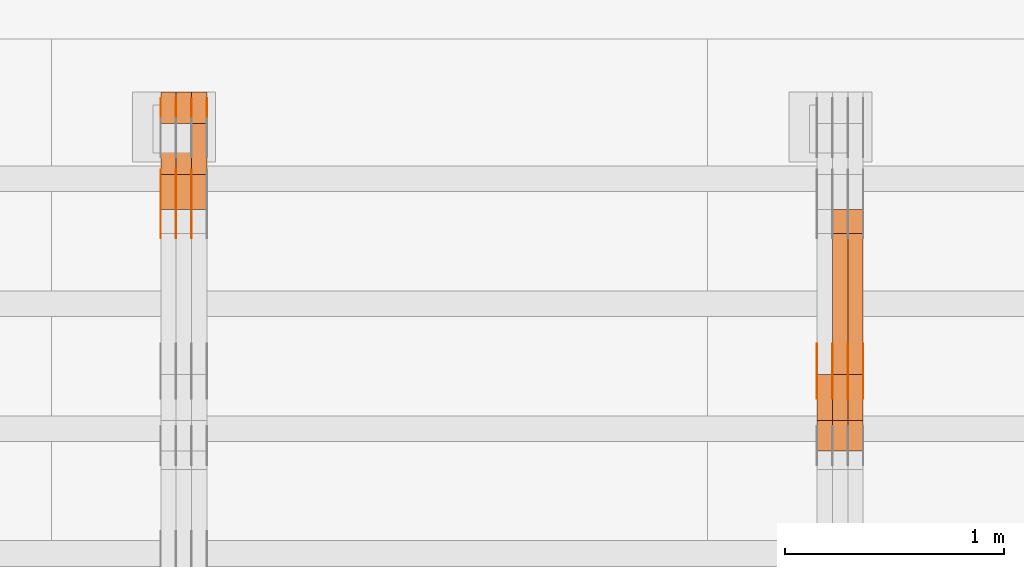
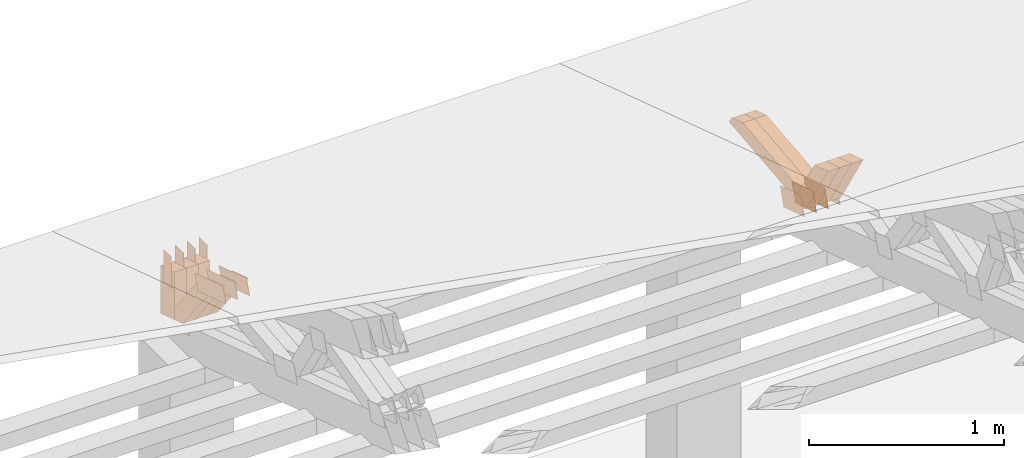
# One storey, part 349 of 385: 28 proxies.
"""IFC2X3 building model written with IfcOpenShell, lengths in millimetres."""

from ifc_helpers import new_model, entity, si_unit, converted_unit, derived_unit, direction, frame, frame_2d, origin, place, context, subcontext, project, spatial, polyline, rectangle, outline, extrude, source, transform, mapped, material, type_object, type_shapes, element, save


model = new_model("IFC2X3")

# Units and contexts
model_context = context("Model", 3, precision=0.01, world=origin(), true_north=direction((6.12303176911189e-17, 1.0)))
body_context = subcontext(model_context, "Body", "Model", "MODEL_VIEW")
ifc_project = project(units=[si_unit("LENGTHUNIT", "METRE", prefix="MILLI"), si_unit("AREAUNIT", "SQUARE_METRE"), si_unit("VOLUMEUNIT", "CUBIC_METRE"), converted_unit("PLANEANGLEUNIT", "DEGREE", entity("IfcRatioMeasure", 0.0174532925199433), si_unit("PLANEANGLEUNIT", "RADIAN"), dimensions=[0, 0, 0, 0, 0, 0, 0]), si_unit("MASSUNIT", "GRAM", prefix="KILO"), derived_unit("MASSDENSITYUNIT", [(si_unit("MASSUNIT", "GRAM", prefix="KILO"), 1), (si_unit("LENGTHUNIT", "METRE"), -3)]), si_unit("TIMEUNIT", "SECOND"), si_unit("FREQUENCYUNIT", "HERTZ"), si_unit("THERMODYNAMICTEMPERATUREUNIT", "DEGREE_CELSIUS"), derived_unit("THERMALTRANSMITTANCEUNIT", [(si_unit("MASSUNIT", "GRAM", prefix="KILO"), 1), (si_unit("THERMODYNAMICTEMPERATUREUNIT", "KELVIN"), -1), (si_unit("TIMEUNIT", "SECOND"), -3)]), derived_unit("VOLUMETRICFLOWRATEUNIT", [(si_unit("LENGTHUNIT", "METRE"), 3), (si_unit("TIMEUNIT", "SECOND"), -1)]), si_unit("ELECTRICCURRENTUNIT", "AMPERE"), si_unit("ELECTRICVOLTAGEUNIT", "VOLT"), si_unit("POWERUNIT", "WATT"), si_unit("FORCEUNIT", "NEWTON", prefix="KILO"), si_unit("ILLUMINANCEUNIT", "LUX"), si_unit("LUMINOUSFLUXUNIT", "LUMEN"), si_unit("LUMINOUSINTENSITYUNIT", "CANDELA"), derived_unit("USERDEFINED", [(si_unit("MASSUNIT", "GRAM", prefix="KILO"), -1), (si_unit("LENGTHUNIT", "METRE"), -2), (si_unit("TIMEUNIT", "SECOND"), 3), (si_unit("LUMINOUSFLUXUNIT", "LUMEN"), 1)]), derived_unit("LINEARVELOCITYUNIT", [(si_unit("LENGTHUNIT", "METRE"), 1), (si_unit("TIMEUNIT", "SECOND"), -1)]), si_unit("PRESSUREUNIT", "PASCAL"), derived_unit("USERDEFINED", [(si_unit("LENGTHUNIT", "METRE"), -2), (si_unit("MASSUNIT", "GRAM", prefix="KILO"), 1), (si_unit("TIMEUNIT", "SECOND"), -2)])], contexts=[model_context])

# Site, building, storey
site_placement = place(None, origin())
site = spatial("IfcSite", under=ifc_project, at=site_placement, CompositionType="ELEMENT")
building_placement = place(site_placement, origin())
building = spatial("IfcBuilding", under=site, at=building_placement, CompositionType="ELEMENT")
storey_placement = place(building_placement, origin())
storey = spatial("IfcBuildingStorey", under=building, at=storey_placement, Name="Default", CompositionType="ELEMENT", Elevation=0.0)

# Proxies
ifc_material_1 = material(Name="IfcSurfaceStyle #469548")
building_element_proxy_type_1 = type_object("IfcBuildingElementProxyType", PredefinedType="NOTDEFINED", material=ifc_material_1)
shared_shape_1 = source(origin(), body_context, "Body", "SweptSolid", [
    extrude(outline(polyline([(-112.50003853564, -60.0000121429077), (112.50002982902, -60.0000121429077), (112.500043250865, 60.0000121429077), (-112.500034544245, 60.0000121429077), (-112.50003853564, -60.0000121429077)])), frame((112.500056021398, 60.0000121429077, 0.0), z_axis=(0.0, 0.0, 1.0), x_axis=(-1.0, 0.0, 0.0)), (0.0, 0.0, 1.0), 1.3),
])
type_shapes(building_element_proxy_type_1, [shared_shape_1])
proxy_1_placement = place(building_placement, frame((39386.3, 25310.2182710495, 430.675738123044), z_axis=(-1.0, 0.0, 0.0), x_axis=(0.0, -0.951056516295124, 0.309016994375039)))
element("IfcBuildingElementProxy", 1, at=proxy_1_placement, inside=storey, type_object=building_element_proxy_type_1, material=ifc_material_1, context=body_context, shape_type="MappedRepresentation", body=[
    mapped(shared_shape_1, transform((0.0, 0.0, 0.0), scale=1.0)),
])
ifc_material_2 = material(Name="IfcSurfaceStyle #469491")
building_element_proxy_type_2 = type_object("IfcBuildingElementProxyType", PredefinedType="NOTDEFINED", material=ifc_material_2)
shared_shape_2 = source(origin(), body_context, "Body", "SweptSolid", [
    extrude(outline(polyline([(-112.50003853564, -60.0000121429077), (112.50002982902, -60.0000121429077), (112.500043250865, 60.0000121429077), (-112.500034544245, 60.0000121429077), (-112.50003853564, -60.0000121429077)])), frame((112.500056021398, 60.0000121429077, 0.0), z_axis=(0.0, 0.0, 1.0), x_axis=(-1.0, 0.0, 0.0)), (0.0, 0.0, 1.0), 1.3),
])
type_shapes(building_element_proxy_type_2, [shared_shape_2])
proxy_2_placement = place(building_placement, frame((39315.0, 25310.2182710495, 430.675738123044), z_axis=(-1.0, 0.0, 0.0), x_axis=(0.0, -0.951056516295124, 0.309016994375039)))
element("IfcBuildingElementProxy", 2, at=proxy_2_placement, inside=storey, type_object=building_element_proxy_type_2, material=ifc_material_2, context=body_context, shape_type="MappedRepresentation", body=[
    mapped(shared_shape_2, transform((0.0, 0.0, 0.0), scale=1.0)),
])
ifc_material_3 = material(Name="IfcSurfaceStyle #469434")
building_element_proxy_type_3 = type_object("IfcBuildingElementProxyType", PredefinedType="NOTDEFINED", material=ifc_material_3)
shared_shape_3 = source(origin(), body_context, "Body", "SweptSolid", [
    extrude(outline(polyline([(-112.50003853564, -60.0000121429077), (112.50002982902, -60.0000121429077), (112.500043250865, 60.0000121429077), (-112.500034544245, 60.0000121429077), (-112.50003853564, -60.0000121429077)])), frame((112.500056021398, 60.0000121429077, 0.0), z_axis=(0.0, 0.0, 1.0), x_axis=(-1.0, 0.0, 0.0)), (0.0, 0.0, 1.0), 1.3),
])
type_shapes(building_element_proxy_type_3, [shared_shape_3])
proxy_3_placement = place(building_placement, frame((39316.3, 25310.2182710495, 430.675738123044), z_axis=(-1.0, 0.0, 0.0), x_axis=(0.0, -0.951056516295124, 0.309016994375039)))
element("IfcBuildingElementProxy", 3, at=proxy_3_placement, inside=storey, type_object=building_element_proxy_type_3, material=ifc_material_3, context=body_context, shape_type="MappedRepresentation", body=[
    mapped(shared_shape_3, transform((0.0, 0.0, 0.0), scale=1.0)),
])
ifc_material_4 = material(Name="IfcSurfaceStyle #469377")
building_element_proxy_type_4 = type_object("IfcBuildingElementProxyType", PredefinedType="NOTDEFINED", material=ifc_material_4)
shared_shape_4 = source(origin(), body_context, "Body", "SweptSolid", [
    extrude(outline(polyline([(-112.50003853564, -60.0000121429077), (112.50002982902, -60.0000121429077), (112.500043250865, 60.0000121429077), (-112.500034544245, 60.0000121429077), (-112.50003853564, -60.0000121429077)])), frame((112.500056021398, 60.0000121429077, 0.0), z_axis=(0.0, 0.0, 1.0), x_axis=(-1.0, 0.0, 0.0)), (0.0, 0.0, 1.0), 1.29999999999998),
])
type_shapes(building_element_proxy_type_4, [shared_shape_4])
proxy_4_placement = place(building_placement, frame((39245.0, 25310.2182710495, 430.675738123044), z_axis=(-1.0, 0.0, 0.0), x_axis=(0.0, -0.951056516295124, 0.309016994375039)))
element("IfcBuildingElementProxy", 4, at=proxy_4_placement, inside=storey, type_object=building_element_proxy_type_4, material=ifc_material_4, context=body_context, shape_type="MappedRepresentation", body=[
    mapped(shared_shape_4, transform((0.0, 0.0, 0.0), scale=1.0)),
])
ifc_material_5 = material(Name="IfcSurfaceStyle #469320")
building_element_proxy_type_5 = type_object("IfcBuildingElementProxyType", PredefinedType="NOTDEFINED", material=ifc_material_5)
shared_shape_5 = source(origin(), body_context, "Body", "SweptSolid", [
    extrude(outline(polyline([(-112.50003853564, -60.0000121429077), (112.50002982902, -60.0000121429077), (112.500043250865, 60.0000121429077), (-112.500034544245, 60.0000121429077), (-112.50003853564, -60.0000121429077)])), frame((112.500056021398, 60.0000121429077, 0.0), z_axis=(0.0, 0.0, 1.0), x_axis=(-1.0, 0.0, 0.0)), (0.0, 0.0, 1.0), 1.29999999999998),
])
type_shapes(building_element_proxy_type_5, [shared_shape_5])
proxy_5_placement = place(building_placement, frame((39246.3, 25310.2182710495, 430.675738123044), z_axis=(-1.0, 0.0, 0.0), x_axis=(0.0, -0.951056516295124, 0.309016994375039)))
element("IfcBuildingElementProxy", 5, at=proxy_5_placement, inside=storey, type_object=building_element_proxy_type_5, material=ifc_material_5, context=body_context, shape_type="MappedRepresentation", body=[
    mapped(shared_shape_5, transform((0.0, 0.0, 0.0), scale=1.0)),
])
ifc_material_6 = material(Name="IfcSurfaceStyle #469263")
building_element_proxy_type_6 = type_object("IfcBuildingElementProxyType", PredefinedType="NOTDEFINED", material=ifc_material_6)
shared_shape_6 = source(origin(), body_context, "Body", "SweptSolid", [
    extrude(outline(polyline([(-112.50003853564, -60.0000121429077), (112.50002982902, -60.0000121429077), (112.500043250865, 60.0000121429077), (-112.500034544245, 60.0000121429077), (-112.50003853564, -60.0000121429077)])), frame((112.500056021398, 60.0000121429077, 0.0), z_axis=(0.0, 0.0, 1.0), x_axis=(-1.0, 0.0, 0.0)), (0.0, 0.0, 1.0), 1.29999999999999),
])
type_shapes(building_element_proxy_type_6, [shared_shape_6])
proxy_6_placement = place(building_placement, frame((39175.0, 25310.2182710495, 430.675738123044), z_axis=(-1.0, 0.0, 0.0), x_axis=(0.0, -0.951056516295124, 0.309016994375039)))
element("IfcBuildingElementProxy", 6, at=proxy_6_placement, inside=storey, type_object=building_element_proxy_type_6, material=ifc_material_6, context=body_context, shape_type="MappedRepresentation", body=[
    mapped(shared_shape_6, transform((0.0, 0.0, 0.0), scale=1.0)),
])
ifc_material_7 = material(Name="IfcSurfaceStyle #457506")
building_element_proxy_type_7 = type_object("IfcBuildingElementProxyType", Name="T1-W31 457504", PredefinedType="NOTDEFINED", material=ifc_material_7)
shared_shape_7 = source(origin(), body_context, "Body", "SweptSolid", [
    extrude(outline(polyline([(-201.245318299844, -47.5000121670808), (204.413774229459, -47.5000121670808), (182.034306640891, 5.35692244583164e-05), (126.70380769348, 47.4999853824686), (-311.906570263987, 47.4999853824686), (-201.245318299844, -47.5000121670808)])), frame((204.413774229459, 47.5002684334588, 0.0), z_axis=(0.0, 0.0, 1.0), x_axis=(-1.0, 0.0, 0.0)), (0.0, 0.0, 1.0), 70.0),
])
type_shapes(building_element_proxy_type_7, [shared_shape_7])
proxy_7_placement = place(building_placement, frame((39385.0, 25127.5652647985, 487.27008059185), z_axis=(-1.0, 0.0, 0.0), x_axis=(0.0, -0.520333970303023, 0.853962855953755)))
element("IfcBuildingElementProxy", 7, at=proxy_7_placement, inside=storey, type_object=building_element_proxy_type_7, material=ifc_material_7, Name="T1-W31", context=body_context, shape_type="MappedRepresentation", body=[
    mapped(shared_shape_7, transform((0.0, 0.0, 0.0), scale=1.0)),
])
ifc_material_8 = material(Name="IfcSurfaceStyle #457440")
building_element_proxy_type_8 = type_object("IfcBuildingElementProxyType", Name="T1-W31 457438", PredefinedType="NOTDEFINED", material=ifc_material_8)
shared_shape_8 = source(origin(), body_context, "Body", "SweptSolid", [
    extrude(outline(polyline([(-201.245318299844, -47.5000121670808), (204.413774229459, -47.5000121670808), (182.034306640891, 5.35692244583164e-05), (126.70380769348, 47.4999853824686), (-311.906570263987, 47.4999853824686), (-201.245318299844, -47.5000121670808)])), frame((204.413774229459, 47.5002684334588, 0.0), z_axis=(0.0, 0.0, 1.0), x_axis=(-1.0, 0.0, 0.0)), (0.0, 0.0, 1.0), 70.0),
])
type_shapes(building_element_proxy_type_8, [shared_shape_8])
proxy_8_placement = place(building_placement, frame((39315.0, 25127.5652647985, 487.27008059185), z_axis=(-1.0, 0.0, 0.0), x_axis=(0.0, -0.520333970303023, 0.853962855953755)))
element("IfcBuildingElementProxy", 8, at=proxy_8_placement, inside=storey, type_object=building_element_proxy_type_8, material=ifc_material_8, Name="T1-W31", context=body_context, shape_type="MappedRepresentation", body=[
    mapped(shared_shape_8, transform((0.0, 0.0, 0.0), scale=1.0)),
])
ifc_material_9 = material(Name="IfcSurfaceStyle #457374")
building_element_proxy_type_9 = type_object("IfcBuildingElementProxyType", Name="T1-W31 457372", PredefinedType="NOTDEFINED", material=ifc_material_9)
shared_shape_9 = source(origin(), body_context, "Body", "SweptSolid", [
    extrude(outline(polyline([(-201.245318299844, -47.5000121670808), (204.413774229459, -47.5000121670808), (182.034306640891, 5.35692244583164e-05), (126.70380769348, 47.4999853824686), (-311.906570263987, 47.4999853824686), (-201.245318299844, -47.5000121670808)])), frame((204.413774229459, 47.5002684334588, 0.0), z_axis=(0.0, 0.0, 1.0), x_axis=(-1.0, 0.0, 0.0)), (0.0, 0.0, 1.0), 70.0),
])
type_shapes(building_element_proxy_type_9, [shared_shape_9])
proxy_9_placement = place(building_placement, frame((39245.0, 25127.5652647985, 487.27008059185), z_axis=(-1.0, 0.0, 0.0), x_axis=(0.0, -0.520333970303023, 0.853962855953755)))
element("IfcBuildingElementProxy", 9, at=proxy_9_placement, inside=storey, type_object=building_element_proxy_type_9, material=ifc_material_9, Name="T1-W31", context=body_context, shape_type="MappedRepresentation", body=[
    mapped(shared_shape_9, transform((0.0, 0.0, 0.0), scale=1.0)),
])
ifc_material_10 = material(Name="IfcSurfaceStyle #457110")
building_element_proxy_type_10 = type_object("IfcBuildingElementProxyType", Name="T1-W4 457108", PredefinedType="NOTDEFINED", material=ifc_material_10)
shared_shape_10 = source(origin(), body_context, "Body", "SweptSolid", [
    extrude(outline(polyline([(-510.077325435179, -47.4999981284922), (188.854793418912, -47.4999981284922), (294.906688207675, 1.67015383116809e-05), (324.289382923648, 47.499989777723), (-297.973539115057, 47.4999897777231), (-510.077325435179, -47.4999981284922)])), frame((324.289382923648, 47.5000278316275, 0.0), z_axis=(0.0, 0.0, 1.0), x_axis=(-1.0, 0.0, 0.0)), (0.0, 0.0, 1.0), 70.0),
])
type_shapes(building_element_proxy_type_10, [shared_shape_10])
proxy_10_placement = place(building_placement, frame((39385.0, 25996.2241251556, 525.69905884318), z_axis=(-1.0, 0.0, 0.0), x_axis=(0.0, -0.994287125203057, -0.106738524701444)))
element("IfcBuildingElementProxy", 10, at=proxy_10_placement, inside=storey, type_object=building_element_proxy_type_10, material=ifc_material_10, Name="T1-W4", context=body_context, shape_type="MappedRepresentation", body=[
    mapped(shared_shape_10, transform((0.0, 0.0, 0.0), scale=1.0)),
])
ifc_material_11 = material(Name="IfcSurfaceStyle #457044")
building_element_proxy_type_11 = type_object("IfcBuildingElementProxyType", Name="T1-W4 457042", PredefinedType="NOTDEFINED", material=ifc_material_11)
shared_shape_11 = source(origin(), body_context, "Body", "SweptSolid", [
    extrude(outline(polyline([(-510.077325435179, -47.4999981284922), (188.854793418912, -47.4999981284922), (294.906688207675, 1.67015383116809e-05), (324.289382923648, 47.499989777723), (-297.973539115057, 47.4999897777231), (-510.077325435179, -47.4999981284922)])), frame((324.289382923648, 47.5000278316275, 0.0), z_axis=(0.0, 0.0, 1.0), x_axis=(-1.0, 0.0, 0.0)), (0.0, 0.0, 1.0), 70.0),
])
type_shapes(building_element_proxy_type_11, [shared_shape_11])
proxy_11_placement = place(building_placement, frame((39315.0, 25996.2241251556, 525.69905884318), z_axis=(-1.0, 0.0, 0.0), x_axis=(0.0, -0.994287125203057, -0.106738524701444)))
element("IfcBuildingElementProxy", 11, at=proxy_11_placement, inside=storey, type_object=building_element_proxy_type_11, material=ifc_material_11, Name="T1-W4", context=body_context, shape_type="MappedRepresentation", body=[
    mapped(shared_shape_11, transform((0.0, 0.0, 0.0), scale=1.0)),
])
ifc_material_12 = material(Name="IfcSurfaceStyle #434375")
building_element_proxy_type_12 = type_object("IfcBuildingElementProxyType", PredefinedType="NOTDEFINED", material=ifc_material_12)
shared_shape_12 = source(origin(), body_context, "Body", "SweptSolid", [
    extrude(outline(polyline([(-149.999901061401, -48.0000057587028), (150.000035297123, -48.0000057587028), (149.999910491851, 48.0000057587028), (-150.000044727574, 48.0000057587028), (-149.999901061401, -48.0000057587028)])), frame((150.000035297123, 48.0000632585775, 0.0), z_axis=(0.0, 0.0, 1.0), x_axis=(-1.0, 0.0, 0.0)), (0.0, 0.0, 1.0), 1.29999999999999),
])
type_shapes(building_element_proxy_type_12, [shared_shape_12])
proxy_12_placement = place(building_placement, frame((36315.0, 26115.0176968219, 469.58296924555), z_axis=(-1.0, 0.0, 0.0), x_axis=(0.0, -0.951056516295154, 0.309016994374948)))
element("IfcBuildingElementProxy", 12, at=proxy_12_placement, inside=storey, type_object=building_element_proxy_type_12, material=ifc_material_12, context=body_context, shape_type="MappedRepresentation", body=[
    mapped(shared_shape_12, transform((0.0, 0.0, 0.0), scale=1.0)),
])
ifc_material_13 = material(Name="IfcSurfaceStyle #434318")
building_element_proxy_type_13 = type_object("IfcBuildingElementProxyType", PredefinedType="NOTDEFINED", material=ifc_material_13)
shared_shape_13 = source(origin(), body_context, "Body", "SweptSolid", [
    extrude(outline(polyline([(-149.999901061401, -48.0000057587028), (150.000035297123, -48.0000057587028), (149.999910491851, 48.0000057587028), (-150.000044727574, 48.0000057587028), (-149.999901061401, -48.0000057587028)])), frame((150.000035297123, 48.0000632585775, 0.0), z_axis=(0.0, 0.0, 1.0), x_axis=(-1.0, 0.0, 0.0)), (0.0, 0.0, 1.0), 1.29999999999999),
])
type_shapes(building_element_proxy_type_13, [shared_shape_13])
proxy_13_placement = place(building_placement, frame((36316.3, 26115.0176968219, 469.58296924555), z_axis=(-1.0, 0.0, 0.0), x_axis=(0.0, -0.951056516295154, 0.309016994374948)))
element("IfcBuildingElementProxy", 13, at=proxy_13_placement, inside=storey, type_object=building_element_proxy_type_13, material=ifc_material_13, context=body_context, shape_type="MappedRepresentation", body=[
    mapped(shared_shape_13, transform((0.0, 0.0, 0.0), scale=1.0)),
])
ifc_material_14 = material(Name="IfcSurfaceStyle #434261")
building_element_proxy_type_14 = type_object("IfcBuildingElementProxyType", PredefinedType="NOTDEFINED", material=ifc_material_14)
shared_shape_14 = source(origin(), body_context, "Body", "SweptSolid", [
    extrude(outline(polyline([(-149.999901061401, -48.0000057587028), (150.000035297123, -48.0000057587028), (149.999910491851, 48.0000057587028), (-150.000044727574, 48.0000057587028), (-149.999901061401, -48.0000057587028)])), frame((150.000035297123, 48.0000632585775, 0.0), z_axis=(0.0, 0.0, 1.0), x_axis=(-1.0, 0.0, 0.0)), (0.0, 0.0, 1.0), 1.29999999999998),
])
type_shapes(building_element_proxy_type_14, [shared_shape_14])
proxy_14_placement = place(building_placement, frame((36245.0, 26115.0176968219, 469.58296924555), z_axis=(-1.0, 0.0, 0.0), x_axis=(0.0, -0.951056516295154, 0.309016994374948)))
element("IfcBuildingElementProxy", 14, at=proxy_14_placement, inside=storey, type_object=building_element_proxy_type_14, material=ifc_material_14, context=body_context, shape_type="MappedRepresentation", body=[
    mapped(shared_shape_14, transform((0.0, 0.0, 0.0), scale=1.0)),
])
ifc_material_15 = material(Name="IfcSurfaceStyle #434204")
building_element_proxy_type_15 = type_object("IfcBuildingElementProxyType", PredefinedType="NOTDEFINED", material=ifc_material_15)
shared_shape_15 = source(origin(), body_context, "Body", "SweptSolid", [
    extrude(outline(polyline([(-149.999901061401, -48.0000057587028), (150.000035297123, -48.0000057587028), (149.999910491851, 48.0000057587028), (-150.000044727574, 48.0000057587028), (-149.999901061401, -48.0000057587028)])), frame((150.000035297123, 48.0000632585775, 0.0), z_axis=(0.0, 0.0, 1.0), x_axis=(-1.0, 0.0, 0.0)), (0.0, 0.0, 1.0), 1.29999999999998),
])
type_shapes(building_element_proxy_type_15, [shared_shape_15])
proxy_15_placement = place(building_placement, frame((36246.3, 26115.0176968219, 469.58296924555), z_axis=(-1.0, 0.0, 0.0), x_axis=(0.0, -0.951056516295154, 0.309016994374948)))
element("IfcBuildingElementProxy", 15, at=proxy_15_placement, inside=storey, type_object=building_element_proxy_type_15, material=ifc_material_15, context=body_context, shape_type="MappedRepresentation", body=[
    mapped(shared_shape_15, transform((0.0, 0.0, 0.0), scale=1.0)),
])
ifc_material_16 = material(Name="IfcSurfaceStyle #434147")
building_element_proxy_type_16 = type_object("IfcBuildingElementProxyType", PredefinedType="NOTDEFINED", material=ifc_material_16)
shared_shape_16 = source(origin(), body_context, "Body", "SweptSolid", [
    extrude(outline(polyline([(-149.999901061401, -48.0000057587028), (150.000035297123, -48.0000057587028), (149.999910491851, 48.0000057587028), (-150.000044727574, 48.0000057587028), (-149.999901061401, -48.0000057587028)])), frame((150.000035297123, 48.0000632585775, 0.0), z_axis=(0.0, 0.0, 1.0), x_axis=(-1.0, 0.0, 0.0)), (0.0, 0.0, 1.0), 1.29999999999998),
])
type_shapes(building_element_proxy_type_16, [shared_shape_16])
proxy_16_placement = place(building_placement, frame((36175.0, 26115.0176968219, 469.58296924555), z_axis=(-1.0, 0.0, 0.0), x_axis=(0.0, -0.951056516295154, 0.309016994374948)))
element("IfcBuildingElementProxy", 16, at=proxy_16_placement, inside=storey, type_object=building_element_proxy_type_16, material=ifc_material_16, context=body_context, shape_type="MappedRepresentation", body=[
    mapped(shared_shape_16, transform((0.0, 0.0, 0.0), scale=1.0)),
])
ifc_material_17 = material(Name="IfcSurfaceStyle #434090")
building_element_proxy_type_17 = type_object("IfcBuildingElementProxyType", PredefinedType="NOTDEFINED", material=ifc_material_17)
shared_shape_17 = source(origin(), body_context, "Body", "SweptSolid", [
    extrude(rectangle(XDim=200.0, YDim=84.0000000000005, at=frame_2d((-2.1316282072803e-14, 1.06581410364015e-14), x_axis=(1.0, 0.0))), frame((100.0, 42.0, 0.0), z_axis=(0.0, 0.0, 1.0), x_axis=(-1.0, 0.0, 0.0)), (0.0, 0.0, 1.0), 1.3),
])
type_shapes(building_element_proxy_type_17, [shared_shape_17])
proxy_17_placement = place(building_placement, frame((36386.3, 26469.5000000002, 518.521545410156), z_axis=(-1.0, 0.0, 0.0), x_axis=(0.0, 0.0, -1.0)))
element("IfcBuildingElementProxy", 17, at=proxy_17_placement, inside=storey, type_object=building_element_proxy_type_17, material=ifc_material_17, context=body_context, shape_type="MappedRepresentation", body=[
    mapped(shared_shape_17, transform((0.0, 0.0, 0.0), scale=1.0)),
])
ifc_material_18 = material(Name="IfcSurfaceStyle #434033")
building_element_proxy_type_18 = type_object("IfcBuildingElementProxyType", PredefinedType="NOTDEFINED", material=ifc_material_18)
shared_shape_18 = source(origin(), body_context, "Body", "SweptSolid", [
    extrude(rectangle(XDim=200.0, YDim=84.0000000000005, at=frame_2d((-2.1316282072803e-14, 1.06581410364015e-14), x_axis=(1.0, 0.0))), frame((100.0, 42.0, 0.0), z_axis=(0.0, 0.0, 1.0), x_axis=(-1.0, 0.0, 0.0)), (0.0, 0.0, 1.0), 1.3),
])
type_shapes(building_element_proxy_type_18, [shared_shape_18])
proxy_18_placement = place(building_placement, frame((36315.0, 26469.5000000002, 518.521545410156), z_axis=(-1.0, 0.0, 0.0), x_axis=(0.0, 0.0, -1.0)))
element("IfcBuildingElementProxy", 18, at=proxy_18_placement, inside=storey, type_object=building_element_proxy_type_18, material=ifc_material_18, context=body_context, shape_type="MappedRepresentation", body=[
    mapped(shared_shape_18, transform((0.0, 0.0, 0.0), scale=1.0)),
])
ifc_material_19 = material(Name="IfcSurfaceStyle #433976")
building_element_proxy_type_19 = type_object("IfcBuildingElementProxyType", PredefinedType="NOTDEFINED", material=ifc_material_19)
shared_shape_19 = source(origin(), body_context, "Body", "SweptSolid", [
    extrude(rectangle(XDim=200.0, YDim=84.0000000000005, at=frame_2d((-2.1316282072803e-14, 1.06581410364015e-14), x_axis=(1.0, 0.0))), frame((100.0, 42.0, 0.0), z_axis=(0.0, 0.0, 1.0), x_axis=(-1.0, 0.0, 0.0)), (0.0, 0.0, 1.0), 1.3),
])
type_shapes(building_element_proxy_type_19, [shared_shape_19])
proxy_19_placement = place(building_placement, frame((36316.3, 26469.5000000002, 518.521545410156), z_axis=(-1.0, 0.0, 0.0), x_axis=(0.0, 0.0, -1.0)))
element("IfcBuildingElementProxy", 19, at=proxy_19_placement, inside=storey, type_object=building_element_proxy_type_19, material=ifc_material_19, context=body_context, shape_type="MappedRepresentation", body=[
    mapped(shared_shape_19, transform((0.0, 0.0, 0.0), scale=1.0)),
])
ifc_material_20 = material(Name="IfcSurfaceStyle #433919")
building_element_proxy_type_20 = type_object("IfcBuildingElementProxyType", PredefinedType="NOTDEFINED", material=ifc_material_20)
shared_shape_20 = source(origin(), body_context, "Body", "SweptSolid", [
    extrude(rectangle(XDim=200.0, YDim=84.0000000000005, at=frame_2d((-2.1316282072803e-14, 1.06581410364015e-14), x_axis=(1.0, 0.0))), frame((100.0, 42.0, 0.0), z_axis=(0.0, 0.0, 1.0), x_axis=(-1.0, 0.0, 0.0)), (0.0, 0.0, 1.0), 1.29999999999998),
])
type_shapes(building_element_proxy_type_20, [shared_shape_20])
proxy_20_placement = place(building_placement, frame((36245.0, 26469.5000000002, 518.521545410156), z_axis=(-1.0, 0.0, 0.0), x_axis=(0.0, 0.0, -1.0)))
element("IfcBuildingElementProxy", 20, at=proxy_20_placement, inside=storey, type_object=building_element_proxy_type_20, material=ifc_material_20, context=body_context, shape_type="MappedRepresentation", body=[
    mapped(shared_shape_20, transform((0.0, 0.0, 0.0), scale=1.0)),
])
ifc_material_21 = material(Name="IfcSurfaceStyle #433862")
building_element_proxy_type_21 = type_object("IfcBuildingElementProxyType", PredefinedType="NOTDEFINED", material=ifc_material_21)
shared_shape_21 = source(origin(), body_context, "Body", "SweptSolid", [
    extrude(rectangle(XDim=200.0, YDim=84.0000000000005, at=frame_2d((-2.1316282072803e-14, 1.06581410364015e-14), x_axis=(1.0, 0.0))), frame((100.0, 42.0, 0.0), z_axis=(0.0, 0.0, 1.0), x_axis=(-1.0, 0.0, 0.0)), (0.0, 0.0, 1.0), 1.29999999999998),
])
type_shapes(building_element_proxy_type_21, [shared_shape_21])
proxy_21_placement = place(building_placement, frame((36246.3, 26469.5000000002, 518.521545410156), z_axis=(-1.0, 0.0, 0.0), x_axis=(0.0, 0.0, -1.0)))
element("IfcBuildingElementProxy", 21, at=proxy_21_placement, inside=storey, type_object=building_element_proxy_type_21, material=ifc_material_21, context=body_context, shape_type="MappedRepresentation", body=[
    mapped(shared_shape_21, transform((0.0, 0.0, 0.0), scale=1.0)),
])
ifc_material_22 = material(Name="IfcSurfaceStyle #433805")
building_element_proxy_type_22 = type_object("IfcBuildingElementProxyType", PredefinedType="NOTDEFINED", material=ifc_material_22)
shared_shape_22 = source(origin(), body_context, "Body", "SweptSolid", [
    extrude(rectangle(XDim=200.0, YDim=84.0000000000005, at=frame_2d((-2.1316282072803e-14, 1.06581410364015e-14), x_axis=(1.0, 0.0))), frame((100.0, 42.0, 0.0), z_axis=(0.0, 0.0, 1.0), x_axis=(-1.0, 0.0, 0.0)), (0.0, 0.0, 1.0), 1.29999999999999),
])
type_shapes(building_element_proxy_type_22, [shared_shape_22])
proxy_22_placement = place(building_placement, frame((36175.0, 26469.5000000002, 518.521545410156), z_axis=(-1.0, 0.0, 0.0), x_axis=(0.0, 0.0, -1.0)))
element("IfcBuildingElementProxy", 22, at=proxy_22_placement, inside=storey, type_object=building_element_proxy_type_22, material=ifc_material_22, context=body_context, shape_type="MappedRepresentation", body=[
    mapped(shared_shape_22, transform((0.0, 0.0, 0.0), scale=1.0)),
])
ifc_material_23 = material(Name="IfcSurfaceStyle #422282")
building_element_proxy_type_23 = type_object("IfcBuildingElementProxyType", Name="T1-W21 422280", PredefinedType="NOTDEFINED", material=ifc_material_23)
shared_shape_23 = source(origin(), body_context, "Body", "SweptSolid", [
    extrude(outline(polyline([(-209.199362597501, -47.5000308982766), (168.813164734153, -47.5000308982766), (229.900717355638, -2.18385470334148e-05), (159.828709317766, 47.5000418175501), (-349.343228810055, 47.5000418175502), (-209.199362597501, -47.5000308982766)])), frame((229.900720156071, 47.5000418175501, 0.0), z_axis=(0.0, 0.0, 1.0), x_axis=(-1.0, 0.0, 0.0)), (0.0, 0.0, 1.0), 70.0),
])
type_shapes(building_element_proxy_type_23, [shared_shape_23])
proxy_23_placement = place(building_placement, frame((36385.0, 26317.5019908272, 112.518372832984), z_axis=(-1.0, 0.0, 0.0), x_axis=(0.0, -0.613839629272042, 0.789430750310097)))
element("IfcBuildingElementProxy", 23, at=proxy_23_placement, inside=storey, type_object=building_element_proxy_type_23, material=ifc_material_23, Name="T1-W21", context=body_context, shape_type="MappedRepresentation", body=[
    mapped(shared_shape_23, transform((0.0, 0.0, 0.0), scale=1.0)),
])
ifc_material_24 = material(Name="IfcSurfaceStyle #422216")
building_element_proxy_type_24 = type_object("IfcBuildingElementProxyType", Name="T1-W21 422214", PredefinedType="NOTDEFINED", material=ifc_material_24)
shared_shape_24 = source(origin(), body_context, "Body", "SweptSolid", [
    extrude(outline(polyline([(-209.199362597501, -47.5000308982766), (168.813164734153, -47.5000308982766), (229.900717355638, -2.18385470334148e-05), (159.828709317766, 47.5000418175501), (-349.343228810055, 47.5000418175502), (-209.199362597501, -47.5000308982766)])), frame((229.900720156071, 47.5000418175501, 0.0), z_axis=(0.0, 0.0, 1.0), x_axis=(-1.0, 0.0, 0.0)), (0.0, 0.0, 1.0), 70.0),
])
type_shapes(building_element_proxy_type_24, [shared_shape_24])
proxy_24_placement = place(building_placement, frame((36315.0, 26317.5019908272, 112.518372832984), z_axis=(-1.0, 0.0, 0.0), x_axis=(0.0, -0.613839629272042, 0.789430750310097)))
element("IfcBuildingElementProxy", 24, at=proxy_24_placement, inside=storey, type_object=building_element_proxy_type_24, material=ifc_material_24, Name="T1-W21", context=body_context, shape_type="MappedRepresentation", body=[
    mapped(shared_shape_24, transform((0.0, 0.0, 0.0), scale=1.0)),
])
ifc_material_25 = material(Name="IfcSurfaceStyle #422150")
building_element_proxy_type_25 = type_object("IfcBuildingElementProxyType", Name="T1-W21 422148", PredefinedType="NOTDEFINED", material=ifc_material_25)
shared_shape_25 = source(origin(), body_context, "Body", "SweptSolid", [
    extrude(outline(polyline([(-209.199362597501, -47.5000308982766), (168.813164734153, -47.5000308982766), (229.900717355638, -2.18385470334148e-05), (159.828709317766, 47.5000418175501), (-349.343228810055, 47.5000418175502), (-209.199362597501, -47.5000308982766)])), frame((229.900720156071, 47.5000418175501, 0.0), z_axis=(0.0, 0.0, 1.0), x_axis=(-1.0, 0.0, 0.0)), (0.0, 0.0, 1.0), 70.0),
])
type_shapes(building_element_proxy_type_25, [shared_shape_25])
proxy_25_placement = place(building_placement, frame((36245.0, 26317.5019908272, 112.518372832984), z_axis=(-1.0, 0.0, 0.0), x_axis=(0.0, -0.613839629272042, 0.789430750310097)))
element("IfcBuildingElementProxy", 25, at=proxy_25_placement, inside=storey, type_object=building_element_proxy_type_25, material=ifc_material_25, Name="T1-W21", context=body_context, shape_type="MappedRepresentation", body=[
    mapped(shared_shape_25, transform((0.0, 0.0, 0.0), scale=1.0)),
])
ifc_material_26 = material(Name="IfcSurfaceStyle #421715")
building_element_proxy_type_26 = type_object("IfcBuildingElementProxyType", Name="T1-E2 421713", PredefinedType="NOTDEFINED", material=ifc_material_26)
shared_shape_26 = source(origin(), body_context, "Body", "SweptSolid", [
    extrude(outline(polyline([(-126.644535064697, -72.4999999999998), (173.757884979248, -72.4999999999998), (126.644542694092, 72.4999999999998), (-173.757892608642, 72.4999999999998), (-126.644535064697, -72.4999999999998)])), frame((173.757890653796, 72.5000000000002, 0.0), z_axis=(0.0, 0.0, 1.0), x_axis=(-1.0, 0.0, 0.0)), (0.0, 0.0, 1.0), 70.0),
])
type_shapes(building_element_proxy_type_26, [shared_shape_26])
proxy_26_placement = place(building_placement, frame((36385.0, 26500.0, 442.078222227283), z_axis=(-1.0, 0.0, 0.0), x_axis=(0.0, 0.0, -1.0)))
element("IfcBuildingElementProxy", 26, at=proxy_26_placement, inside=storey, type_object=building_element_proxy_type_26, material=ifc_material_26, Name="T1-E2", context=body_context, shape_type="MappedRepresentation", body=[
    mapped(shared_shape_26, transform((0.0, 0.0, 0.0), scale=1.0)),
])
ifc_material_27 = material(Name="IfcSurfaceStyle #421658")
building_element_proxy_type_27 = type_object("IfcBuildingElementProxyType", Name="T1-E2 421656", PredefinedType="NOTDEFINED", material=ifc_material_27)
shared_shape_27 = source(origin(), body_context, "Body", "SweptSolid", [
    extrude(outline(polyline([(-126.644535064697, -72.4999999999998), (173.757884979248, -72.4999999999998), (126.644542694092, 72.4999999999998), (-173.757892608642, 72.4999999999998), (-126.644535064697, -72.4999999999998)])), frame((173.757890653796, 72.5000000000002, 0.0), z_axis=(0.0, 0.0, 1.0), x_axis=(-1.0, 0.0, 0.0)), (0.0, 0.0, 1.0), 70.0),
])
type_shapes(building_element_proxy_type_27, [shared_shape_27])
proxy_27_placement = place(building_placement, frame((36315.0, 26500.0, 442.078222227283), z_axis=(-1.0, 0.0, 0.0), x_axis=(0.0, 0.0, -1.0)))
element("IfcBuildingElementProxy", 27, at=proxy_27_placement, inside=storey, type_object=building_element_proxy_type_27, material=ifc_material_27, Name="T1-E2", context=body_context, shape_type="MappedRepresentation", body=[
    mapped(shared_shape_27, transform((0.0, 0.0, 0.0), scale=1.0)),
])
ifc_material_28 = material(Name="IfcSurfaceStyle #421601")
building_element_proxy_type_28 = type_object("IfcBuildingElementProxyType", Name="T1-E2 421599", PredefinedType="NOTDEFINED", material=ifc_material_28)
shared_shape_28 = source(origin(), body_context, "Body", "SweptSolid", [
    extrude(outline(polyline([(-126.644535064697, -72.4999999999998), (173.757884979248, -72.4999999999998), (126.644542694092, 72.4999999999998), (-173.757892608642, 72.4999999999998), (-126.644535064697, -72.4999999999998)])), frame((173.757890653796, 72.5000000000002, 0.0), z_axis=(0.0, 0.0, 1.0), x_axis=(-1.0, 0.0, 0.0)), (0.0, 0.0, 1.0), 70.0),
])
type_shapes(building_element_proxy_type_28, [shared_shape_28])
proxy_28_placement = place(building_placement, frame((36245.0, 26500.0, 442.078222227283), z_axis=(-1.0, 0.0, 0.0), x_axis=(0.0, 0.0, -1.0)))
element("IfcBuildingElementProxy", 28, at=proxy_28_placement, inside=storey, type_object=building_element_proxy_type_28, material=ifc_material_28, Name="T1-E2", context=body_context, shape_type="MappedRepresentation", body=[
    mapped(shared_shape_28, transform((0.0, 0.0, 0.0), scale=1.0)),
])

save(model, "model.ifc")
